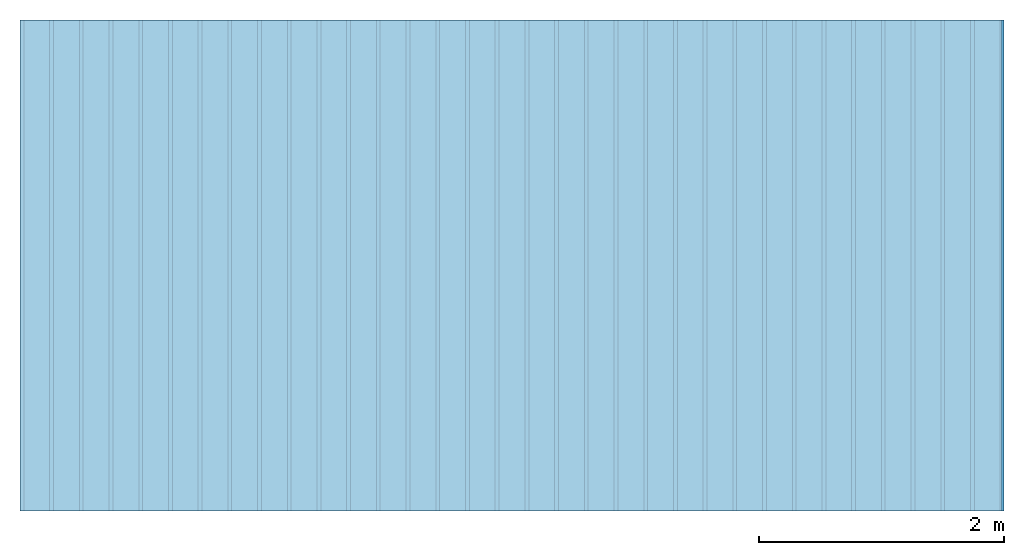
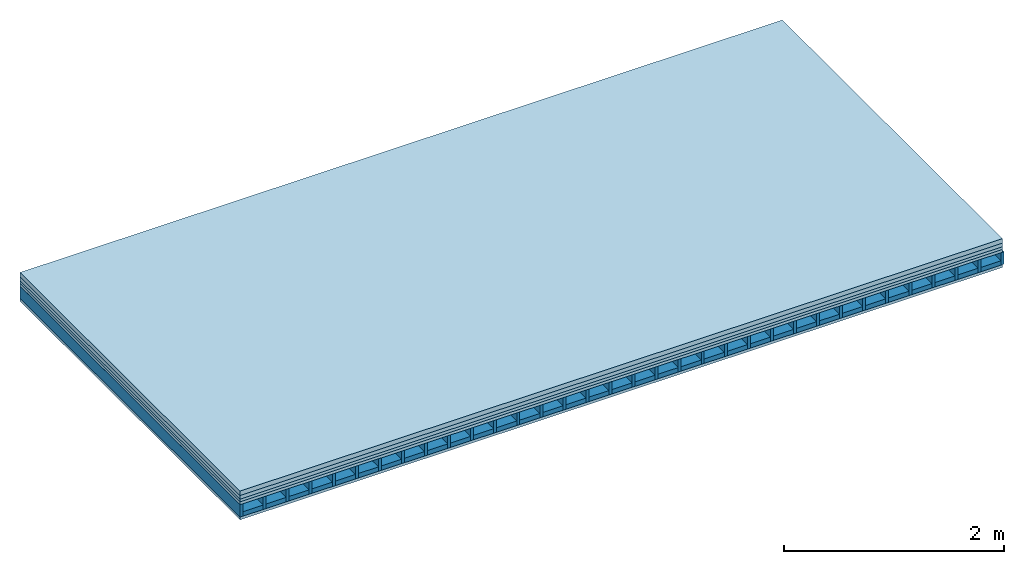
# One storey: 5 plates, 2 members, 1 element without a shape of its own.
"""IFC4 building model written with IfcOpenShell, lengths in metres."""

from ifc_helpers import new_model, si_unit, derived_unit, direction, frame, frame_2d, origin, origin_with_axes, place, context, project, spatial, rectangle, extrude, material, layer, layer_set, type_object, element, aggregate, save


model = new_model("IFC4")

# Units and contexts
plan_context = context("Plan", 3, precision=1e-05, world=origin(), true_north=direction((0.0, 1.0)))
model_context = context("Model", 3, precision=1e-05, world=origin(), true_north=direction((0.0, 1.0)))
ifc_project = project(units=[si_unit("LENGTHUNIT", "METRE"), derived_unit("SOUNDPRESSUREUNIT", [(si_unit("PRESSUREUNIT", "PASCAL", prefix="MICRO"), 0)]), si_unit("ENERGYUNIT", "JOULE", prefix="MEGA"), si_unit("MASSUNIT", "GRAM", prefix="KILO"), derived_unit("THERMALTRANSMITTANCEUNIT", [(si_unit("POWERUNIT", "WATT"), 1), (si_unit("AREAUNIT", "SQUARE_METRE"), -1), (si_unit("THERMODYNAMICTEMPERATUREUNIT", "KELVIN"), -1)]), derived_unit("AREADENSITYUNIT", [(si_unit("MASSUNIT", "GRAM", prefix="KILO"), 1), (si_unit("AREAUNIT", "SQUARE_METRE"), -1)]), derived_unit("USERDEFINED", [(si_unit("ENERGYUNIT", "JOULE", prefix="MEGA"), 1), (si_unit("AREAUNIT", "SQUARE_METRE"), -1)])], contexts=[plan_context, model_context])

# Site, building, storey
site = spatial("IfcSite", under=ifc_project)
building_placement = place(None, origin())
building = spatial("IfcBuilding", under=site, at=building_placement)
storey_placement = place(building_placement, origin())
storey = spatial("IfcBuildingStorey", under=building, at=storey_placement)

# Slab, members, plates
ifc_material_1 = material(Name="Cement screed", Category="04.006")
ifc_layer_1 = layer(ifc_material_1, 0.05, Name="On-material")
ifc_material_2 = material(Name="EP1, 40/35mm")
ifc_layer_2 = layer(ifc_material_2, 0.04, Name="Impact sound insulation")
ifc_material_3 = material(Category="03.011")
ifc_layer_3 = layer(ifc_material_3, 0.03, Name="on Supporting structure")
ifc_material_4 = material(Name="surface element sheathing above")
ifc_layer_4 = layer(ifc_material_4, 0.031, Name="Sub-floor")
ifc_layer_5 = layer(None, 0.138, Name="Supporting structure")
ifc_material_5 = material(Name="surface element sheathing below")
ifc_layer_6 = layer(ifc_material_5, 0.031, Name="Lower layer 1")
ifc_layer_set = layer_set([ifc_layer_1, ifc_layer_2, ifc_layer_3, ifc_layer_4, ifc_layer_5, ifc_layer_6])
slab_type = type_object("IfcSlabType", Name="A2704", PredefinedType="NOTDEFINED", material=ifc_layer_set)
slab_placement = place(None, frame((0.0, 0.0, 0.0), z_axis=(0.0, 0.0, -1.0), x_axis=(1.0, 0.0, 0.0)))
slab = element("IfcSlab", 1, at=slab_placement, inside=storey, type_object=slab_type, material=ifc_layer_set, Name="Slab #1")
ifc_material_6 = material(Name="surface element LFE")
member_1_placement = place(slab_placement, origin())
member_1 = element("IfcMember", 2, at=member_1_placement, material=ifc_material_6, Name="Supporting structure", context=plan_context, shape_type="SweptSolid", body=[
    extrude(rectangle(XDim=0.031, YDim=0.138, at=frame_2d((0.0155, 0.069), x_axis=(1.0, 0.0))), frame((0.0, 4.0, 0.151), z_axis=(0.0, -1.0, 0.0), x_axis=(1.0, 0.0, 0.0)), (0.0, 0.0, 1.0), 4.0),
    extrude(rectangle(XDim=0.031, YDim=0.138, at=frame_2d((0.0155, 0.069), x_axis=(1.0, 0.0))), frame((0.242, 4.0, 0.151), z_axis=(0.0, -1.0, 0.0), x_axis=(1.0, 0.0, 0.0)), (0.0, 0.0, 1.0), 4.0),
    extrude(rectangle(XDim=0.031, YDim=0.138, at=frame_2d((0.0155, 0.069), x_axis=(1.0, 0.0))), frame((0.484, 4.0, 0.151), z_axis=(0.0, -1.0, 0.0), x_axis=(1.0, 0.0, 0.0)), (0.0, 0.0, 1.0), 4.0),
    extrude(rectangle(XDim=0.031, YDim=0.138, at=frame_2d((0.0155, 0.069), x_axis=(1.0, 0.0))), frame((0.726, 4.0, 0.151), z_axis=(0.0, -1.0, 0.0), x_axis=(1.0, 0.0, 0.0)), (0.0, 0.0, 1.0), 4.0),
    extrude(rectangle(XDim=0.031, YDim=0.138, at=frame_2d((0.0155, 0.069), x_axis=(1.0, 0.0))), frame((0.968, 4.0, 0.151), z_axis=(0.0, -1.0, 0.0), x_axis=(1.0, 0.0, 0.0)), (0.0, 0.0, 1.0), 4.0),
    extrude(rectangle(XDim=0.031, YDim=0.138, at=frame_2d((0.0155, 0.069), x_axis=(1.0, 0.0))), frame((1.21, 4.0, 0.151), z_axis=(0.0, -1.0, 0.0), x_axis=(1.0, 0.0, 0.0)), (0.0, 0.0, 1.0), 4.0),
    extrude(rectangle(XDim=0.031, YDim=0.138, at=frame_2d((0.0155, 0.069), x_axis=(1.0, 0.0))), frame((1.452, 4.0, 0.151), z_axis=(0.0, -1.0, 0.0), x_axis=(1.0, 0.0, 0.0)), (0.0, 0.0, 1.0), 4.0),
    extrude(rectangle(XDim=0.031, YDim=0.138, at=frame_2d((0.0155, 0.069), x_axis=(1.0, 0.0))), frame((1.694, 4.0, 0.151), z_axis=(0.0, -1.0, 0.0), x_axis=(1.0, 0.0, 0.0)), (0.0, 0.0, 1.0), 4.0),
    extrude(rectangle(XDim=0.031, YDim=0.138, at=frame_2d((0.0155, 0.069), x_axis=(1.0, 0.0))), frame((1.936, 4.0, 0.151), z_axis=(0.0, -1.0, 0.0), x_axis=(1.0, 0.0, 0.0)), (0.0, 0.0, 1.0), 4.0),
    extrude(rectangle(XDim=0.031, YDim=0.138, at=frame_2d((0.0155, 0.069), x_axis=(1.0, 0.0))), frame((2.178, 4.0, 0.151), z_axis=(0.0, -1.0, 0.0), x_axis=(1.0, 0.0, 0.0)), (0.0, 0.0, 1.0), 4.0),
    extrude(rectangle(XDim=0.031, YDim=0.138, at=frame_2d((0.0155, 0.069), x_axis=(1.0, 0.0))), frame((2.42, 4.0, 0.151), z_axis=(0.0, -1.0, 0.0), x_axis=(1.0, 0.0, 0.0)), (0.0, 0.0, 1.0), 4.0),
    extrude(rectangle(XDim=0.031, YDim=0.138, at=frame_2d((0.0155, 0.069), x_axis=(1.0, 0.0))), frame((2.662, 4.0, 0.151), z_axis=(0.0, -1.0, 0.0), x_axis=(1.0, 0.0, 0.0)), (0.0, 0.0, 1.0), 4.0),
    extrude(rectangle(XDim=0.031, YDim=0.138, at=frame_2d((0.0155, 0.069), x_axis=(1.0, 0.0))), frame((2.904, 4.0, 0.151), z_axis=(0.0, -1.0, 0.0), x_axis=(1.0, 0.0, 0.0)), (0.0, 0.0, 1.0), 4.0),
    extrude(rectangle(XDim=0.031, YDim=0.138, at=frame_2d((0.0155, 0.069), x_axis=(1.0, 0.0))), frame((3.146, 4.0, 0.151), z_axis=(0.0, -1.0, 0.0), x_axis=(1.0, 0.0, 0.0)), (0.0, 0.0, 1.0), 4.0),
    extrude(rectangle(XDim=0.031, YDim=0.138, at=frame_2d((0.0155, 0.069), x_axis=(1.0, 0.0))), frame((3.388, 4.0, 0.151), z_axis=(0.0, -1.0, 0.0), x_axis=(1.0, 0.0, 0.0)), (0.0, 0.0, 1.0), 4.0),
    extrude(rectangle(XDim=0.031, YDim=0.138, at=frame_2d((0.0155, 0.069), x_axis=(1.0, 0.0))), frame((3.63, 4.0, 0.151), z_axis=(0.0, -1.0, 0.0), x_axis=(1.0, 0.0, 0.0)), (0.0, 0.0, 1.0), 4.0),
    extrude(rectangle(XDim=0.031, YDim=0.138, at=frame_2d((0.0155, 0.069), x_axis=(1.0, 0.0))), frame((3.872, 4.0, 0.151), z_axis=(0.0, -1.0, 0.0), x_axis=(1.0, 0.0, 0.0)), (0.0, 0.0, 1.0), 4.0),
    extrude(rectangle(XDim=0.031, YDim=0.138, at=frame_2d((0.0155, 0.069), x_axis=(1.0, 0.0))), frame((4.114, 4.0, 0.151), z_axis=(0.0, -1.0, 0.0), x_axis=(1.0, 0.0, 0.0)), (0.0, 0.0, 1.0), 4.0),
    extrude(rectangle(XDim=0.031, YDim=0.138, at=frame_2d((0.0155, 0.069), x_axis=(1.0, 0.0))), frame((4.356, 4.0, 0.151), z_axis=(0.0, -1.0, 0.0), x_axis=(1.0, 0.0, 0.0)), (0.0, 0.0, 1.0), 4.0),
    extrude(rectangle(XDim=0.031, YDim=0.138, at=frame_2d((0.0155, 0.069), x_axis=(1.0, 0.0))), frame((4.598, 4.0, 0.151), z_axis=(0.0, -1.0, 0.0), x_axis=(1.0, 0.0, 0.0)), (0.0, 0.0, 1.0), 4.0),
    extrude(rectangle(XDim=0.031, YDim=0.138, at=frame_2d((0.0155, 0.069), x_axis=(1.0, 0.0))), frame((4.84, 4.0, 0.151), z_axis=(0.0, -1.0, 0.0), x_axis=(1.0, 0.0, 0.0)), (0.0, 0.0, 1.0), 4.0),
    extrude(rectangle(XDim=0.031, YDim=0.138, at=frame_2d((0.0155, 0.069), x_axis=(1.0, 0.0))), frame((5.082, 4.0, 0.151), z_axis=(0.0, -1.0, 0.0), x_axis=(1.0, 0.0, 0.0)), (0.0, 0.0, 1.0), 4.0),
    extrude(rectangle(XDim=0.031, YDim=0.138, at=frame_2d((0.0155, 0.069), x_axis=(1.0, 0.0))), frame((5.324, 4.0, 0.151), z_axis=(0.0, -1.0, 0.0), x_axis=(1.0, 0.0, 0.0)), (0.0, 0.0, 1.0), 4.0),
    extrude(rectangle(XDim=0.031, YDim=0.138, at=frame_2d((0.0155, 0.069), x_axis=(1.0, 0.0))), frame((5.566, 4.0, 0.151), z_axis=(0.0, -1.0, 0.0), x_axis=(1.0, 0.0, 0.0)), (0.0, 0.0, 1.0), 4.0),
    extrude(rectangle(XDim=0.031, YDim=0.138, at=frame_2d((0.0155, 0.069), x_axis=(1.0, 0.0))), frame((5.808, 4.0, 0.151), z_axis=(0.0, -1.0, 0.0), x_axis=(1.0, 0.0, 0.0)), (0.0, 0.0, 1.0), 4.0),
    extrude(rectangle(XDim=0.031, YDim=0.138, at=frame_2d((0.0155, 0.069), x_axis=(1.0, 0.0))), frame((6.05, 4.0, 0.151), z_axis=(0.0, -1.0, 0.0), x_axis=(1.0, 0.0, 0.0)), (0.0, 0.0, 1.0), 4.0),
    extrude(rectangle(XDim=0.031, YDim=0.138, at=frame_2d((0.0155, 0.069), x_axis=(1.0, 0.0))), frame((6.292, 4.0, 0.151), z_axis=(0.0, -1.0, 0.0), x_axis=(1.0, 0.0, 0.0)), (0.0, 0.0, 1.0), 4.0),
    extrude(rectangle(XDim=0.031, YDim=0.138, at=frame_2d((0.0155, 0.069), x_axis=(1.0, 0.0))), frame((6.534, 4.0, 0.151), z_axis=(0.0, -1.0, 0.0), x_axis=(1.0, 0.0, 0.0)), (0.0, 0.0, 1.0), 4.0),
    extrude(rectangle(XDim=0.031, YDim=0.138, at=frame_2d((0.0155, 0.069), x_axis=(1.0, 0.0))), frame((6.776, 4.0, 0.151), z_axis=(0.0, -1.0, 0.0), x_axis=(1.0, 0.0, 0.0)), (0.0, 0.0, 1.0), 4.0),
    extrude(rectangle(XDim=0.031, YDim=0.138, at=frame_2d((0.0155, 0.069), x_axis=(1.0, 0.0))), frame((7.018, 4.0, 0.151), z_axis=(0.0, -1.0, 0.0), x_axis=(1.0, 0.0, 0.0)), (0.0, 0.0, 1.0), 4.0),
    extrude(rectangle(XDim=0.031, YDim=0.138, at=frame_2d((0.0155, 0.069), x_axis=(1.0, 0.0))), frame((7.26, 4.0, 0.151), z_axis=(0.0, -1.0, 0.0), x_axis=(1.0, 0.0, 0.0)), (0.0, 0.0, 1.0), 4.0),
    extrude(rectangle(XDim=0.031, YDim=0.138, at=frame_2d((0.0155, 0.069), x_axis=(1.0, 0.0))), frame((7.502, 4.0, 0.151), z_axis=(0.0, -1.0, 0.0), x_axis=(1.0, 0.0, 0.0)), (0.0, 0.0, 1.0), 4.0),
    extrude(rectangle(XDim=0.031, YDim=0.138, at=frame_2d((0.0155, 0.069), x_axis=(1.0, 0.0))), frame((7.744, 4.0, 0.151), z_axis=(0.0, -1.0, 0.0), x_axis=(1.0, 0.0, 0.0)), (0.0, 0.0, 1.0), 4.0),
    extrude(rectangle(XDim=0.031, YDim=0.138, at=frame_2d((0.0155, 0.069), x_axis=(1.0, 0.0))), frame((7.986, 4.0, 0.151), z_axis=(0.0, -1.0, 0.0), x_axis=(1.0, 0.0, 0.0)), (0.0, 0.0, 1.0), 4.0),
])
member_2_placement = place(slab_placement, origin())
member_2 = element("IfcMember", 3, at=member_2_placement, material=ifc_material_3, Name="in supporting structure", context=plan_context, shape_type="SweptSolid", body=[
    extrude(rectangle(XDim=0.211, YDim=0.049, at=frame_2d((0.1055, 0.0245), x_axis=(1.0, 0.0))), frame((0.031, 4.0, 0.24), z_axis=(0.0, -1.0, 0.0), x_axis=(1.0, 0.0, 0.0)), (0.0, 0.0, 1.0), 4.0),
    extrude(rectangle(XDim=0.211, YDim=0.049, at=frame_2d((0.1055, 0.0245), x_axis=(1.0, 0.0))), frame((0.273, 4.0, 0.24), z_axis=(0.0, -1.0, 0.0), x_axis=(1.0, 0.0, 0.0)), (0.0, 0.0, 1.0), 4.0),
    extrude(rectangle(XDim=0.211, YDim=0.049, at=frame_2d((0.1055, 0.0245), x_axis=(1.0, 0.0))), frame((0.515, 4.0, 0.24), z_axis=(0.0, -1.0, 0.0), x_axis=(1.0, 0.0, 0.0)), (0.0, 0.0, 1.0), 4.0),
    extrude(rectangle(XDim=0.211, YDim=0.049, at=frame_2d((0.1055, 0.0245), x_axis=(1.0, 0.0))), frame((0.757, 4.0, 0.24), z_axis=(0.0, -1.0, 0.0), x_axis=(1.0, 0.0, 0.0)), (0.0, 0.0, 1.0), 4.0),
    extrude(rectangle(XDim=0.211, YDim=0.049, at=frame_2d((0.1055, 0.0245), x_axis=(1.0, 0.0))), frame((0.999, 4.0, 0.24), z_axis=(0.0, -1.0, 0.0), x_axis=(1.0, 0.0, 0.0)), (0.0, 0.0, 1.0), 4.0),
    extrude(rectangle(XDim=0.211, YDim=0.049, at=frame_2d((0.1055, 0.0245), x_axis=(1.0, 0.0))), frame((1.241, 4.0, 0.24), z_axis=(0.0, -1.0, 0.0), x_axis=(1.0, 0.0, 0.0)), (0.0, 0.0, 1.0), 4.0),
    extrude(rectangle(XDim=0.211, YDim=0.049, at=frame_2d((0.1055, 0.0245), x_axis=(1.0, 0.0))), frame((1.483, 4.0, 0.24), z_axis=(0.0, -1.0, 0.0), x_axis=(1.0, 0.0, 0.0)), (0.0, 0.0, 1.0), 4.0),
    extrude(rectangle(XDim=0.211, YDim=0.049, at=frame_2d((0.1055, 0.0245), x_axis=(1.0, 0.0))), frame((1.725, 4.0, 0.24), z_axis=(0.0, -1.0, 0.0), x_axis=(1.0, 0.0, 0.0)), (0.0, 0.0, 1.0), 4.0),
    extrude(rectangle(XDim=0.211, YDim=0.049, at=frame_2d((0.1055, 0.0245), x_axis=(1.0, 0.0))), frame((1.967, 4.0, 0.24), z_axis=(0.0, -1.0, 0.0), x_axis=(1.0, 0.0, 0.0)), (0.0, 0.0, 1.0), 4.0),
    extrude(rectangle(XDim=0.211, YDim=0.049, at=frame_2d((0.1055, 0.0245), x_axis=(1.0, 0.0))), frame((2.209, 4.0, 0.24), z_axis=(0.0, -1.0, 0.0), x_axis=(1.0, 0.0, 0.0)), (0.0, 0.0, 1.0), 4.0),
    extrude(rectangle(XDim=0.211, YDim=0.049, at=frame_2d((0.1055, 0.0245), x_axis=(1.0, 0.0))), frame((2.451, 4.0, 0.24), z_axis=(0.0, -1.0, 0.0), x_axis=(1.0, 0.0, 0.0)), (0.0, 0.0, 1.0), 4.0),
    extrude(rectangle(XDim=0.211, YDim=0.049, at=frame_2d((0.1055, 0.0245), x_axis=(1.0, 0.0))), frame((2.693, 4.0, 0.24), z_axis=(0.0, -1.0, 0.0), x_axis=(1.0, 0.0, 0.0)), (0.0, 0.0, 1.0), 4.0),
    extrude(rectangle(XDim=0.211, YDim=0.049, at=frame_2d((0.1055, 0.0245), x_axis=(1.0, 0.0))), frame((2.935, 4.0, 0.24), z_axis=(0.0, -1.0, 0.0), x_axis=(1.0, 0.0, 0.0)), (0.0, 0.0, 1.0), 4.0),
    extrude(rectangle(XDim=0.211, YDim=0.049, at=frame_2d((0.1055, 0.0245), x_axis=(1.0, 0.0))), frame((3.177, 4.0, 0.24), z_axis=(0.0, -1.0, 0.0), x_axis=(1.0, 0.0, 0.0)), (0.0, 0.0, 1.0), 4.0),
    extrude(rectangle(XDim=0.211, YDim=0.049, at=frame_2d((0.1055, 0.0245), x_axis=(1.0, 0.0))), frame((3.419, 4.0, 0.24), z_axis=(0.0, -1.0, 0.0), x_axis=(1.0, 0.0, 0.0)), (0.0, 0.0, 1.0), 4.0),
    extrude(rectangle(XDim=0.211, YDim=0.049, at=frame_2d((0.1055, 0.0245), x_axis=(1.0, 0.0))), frame((3.661, 4.0, 0.24), z_axis=(0.0, -1.0, 0.0), x_axis=(1.0, 0.0, 0.0)), (0.0, 0.0, 1.0), 4.0),
    extrude(rectangle(XDim=0.211, YDim=0.049, at=frame_2d((0.1055, 0.0245), x_axis=(1.0, 0.0))), frame((3.903, 4.0, 0.24), z_axis=(0.0, -1.0, 0.0), x_axis=(1.0, 0.0, 0.0)), (0.0, 0.0, 1.0), 4.0),
    extrude(rectangle(XDim=0.211, YDim=0.049, at=frame_2d((0.1055, 0.0245), x_axis=(1.0, 0.0))), frame((4.145, 4.0, 0.24), z_axis=(0.0, -1.0, 0.0), x_axis=(1.0, 0.0, 0.0)), (0.0, 0.0, 1.0), 4.0),
    extrude(rectangle(XDim=0.211, YDim=0.049, at=frame_2d((0.1055, 0.0245), x_axis=(1.0, 0.0))), frame((4.387, 4.0, 0.24), z_axis=(0.0, -1.0, 0.0), x_axis=(1.0, 0.0, 0.0)), (0.0, 0.0, 1.0), 4.0),
    extrude(rectangle(XDim=0.211, YDim=0.049, at=frame_2d((0.1055, 0.0245), x_axis=(1.0, 0.0))), frame((4.629, 4.0, 0.24), z_axis=(0.0, -1.0, 0.0), x_axis=(1.0, 0.0, 0.0)), (0.0, 0.0, 1.0), 4.0),
    extrude(rectangle(XDim=0.211, YDim=0.049, at=frame_2d((0.1055, 0.0245), x_axis=(1.0, 0.0))), frame((4.871, 4.0, 0.24), z_axis=(0.0, -1.0, 0.0), x_axis=(1.0, 0.0, 0.0)), (0.0, 0.0, 1.0), 4.0),
    extrude(rectangle(XDim=0.211, YDim=0.049, at=frame_2d((0.1055, 0.0245), x_axis=(1.0, 0.0))), frame((5.113, 4.0, 0.24), z_axis=(0.0, -1.0, 0.0), x_axis=(1.0, 0.0, 0.0)), (0.0, 0.0, 1.0), 4.0),
    extrude(rectangle(XDim=0.211, YDim=0.049, at=frame_2d((0.1055, 0.0245), x_axis=(1.0, 0.0))), frame((5.355, 4.0, 0.24), z_axis=(0.0, -1.0, 0.0), x_axis=(1.0, 0.0, 0.0)), (0.0, 0.0, 1.0), 4.0),
    extrude(rectangle(XDim=0.211, YDim=0.049, at=frame_2d((0.1055, 0.0245), x_axis=(1.0, 0.0))), frame((5.597, 4.0, 0.24), z_axis=(0.0, -1.0, 0.0), x_axis=(1.0, 0.0, 0.0)), (0.0, 0.0, 1.0), 4.0),
    extrude(rectangle(XDim=0.211, YDim=0.049, at=frame_2d((0.1055, 0.0245), x_axis=(1.0, 0.0))), frame((5.839, 4.0, 0.24), z_axis=(0.0, -1.0, 0.0), x_axis=(1.0, 0.0, 0.0)), (0.0, 0.0, 1.0), 4.0),
    extrude(rectangle(XDim=0.211, YDim=0.049, at=frame_2d((0.1055, 0.0245), x_axis=(1.0, 0.0))), frame((6.081, 4.0, 0.24), z_axis=(0.0, -1.0, 0.0), x_axis=(1.0, 0.0, 0.0)), (0.0, 0.0, 1.0), 4.0),
    extrude(rectangle(XDim=0.211, YDim=0.049, at=frame_2d((0.1055, 0.0245), x_axis=(1.0, 0.0))), frame((6.323, 4.0, 0.24), z_axis=(0.0, -1.0, 0.0), x_axis=(1.0, 0.0, 0.0)), (0.0, 0.0, 1.0), 4.0),
    extrude(rectangle(XDim=0.211, YDim=0.049, at=frame_2d((0.1055, 0.0245), x_axis=(1.0, 0.0))), frame((6.565, 4.0, 0.24), z_axis=(0.0, -1.0, 0.0), x_axis=(1.0, 0.0, 0.0)), (0.0, 0.0, 1.0), 4.0),
    extrude(rectangle(XDim=0.211, YDim=0.049, at=frame_2d((0.1055, 0.0245), x_axis=(1.0, 0.0))), frame((6.807, 4.0, 0.24), z_axis=(0.0, -1.0, 0.0), x_axis=(1.0, 0.0, 0.0)), (0.0, 0.0, 1.0), 4.0),
    extrude(rectangle(XDim=0.211, YDim=0.049, at=frame_2d((0.1055, 0.0245), x_axis=(1.0, 0.0))), frame((7.049, 4.0, 0.24), z_axis=(0.0, -1.0, 0.0), x_axis=(1.0, 0.0, 0.0)), (0.0, 0.0, 1.0), 4.0),
    extrude(rectangle(XDim=0.211, YDim=0.049, at=frame_2d((0.1055, 0.0245), x_axis=(1.0, 0.0))), frame((7.291, 4.0, 0.24), z_axis=(0.0, -1.0, 0.0), x_axis=(1.0, 0.0, 0.0)), (0.0, 0.0, 1.0), 4.0),
    extrude(rectangle(XDim=0.211, YDim=0.049, at=frame_2d((0.1055, 0.0245), x_axis=(1.0, 0.0))), frame((7.533, 4.0, 0.24), z_axis=(0.0, -1.0, 0.0), x_axis=(1.0, 0.0, 0.0)), (0.0, 0.0, 1.0), 4.0),
    extrude(rectangle(XDim=0.211, YDim=0.049, at=frame_2d((0.1055, 0.0245), x_axis=(1.0, 0.0))), frame((7.775, 4.0, 0.24), z_axis=(0.0, -1.0, 0.0), x_axis=(1.0, 0.0, 0.0)), (0.0, 0.0, 1.0), 4.0),
])
plate_1_placement = place(slab_placement, origin())
plate_1 = element("IfcPlate", 4, at=plate_1_placement, material=ifc_material_1, Name="On-material", context=plan_context, shape_type="SweptSolid", body=[
    extrude(rectangle(XDim=8.0, YDim=4.0, at=frame_2d((4.0, 2.0), x_axis=(1.0, 0.0))), origin_with_axes(), (0.0, 0.0, 1.0), 0.05),
])
plate_2_placement = place(slab_placement, origin())
plate_2 = element("IfcPlate", 5, at=plate_2_placement, material=ifc_material_2, Name="Impact sound insulation", context=plan_context, shape_type="SweptSolid", body=[
    extrude(rectangle(XDim=8.0, YDim=4.0, at=frame_2d((4.0, 2.0), x_axis=(1.0, 0.0))), frame((0.0, 0.0, 0.05), z_axis=(0.0, 0.0, 1.0), x_axis=(1.0, 0.0, 0.0)), (0.0, 0.0, 1.0), 0.04),
])
plate_3_placement = place(slab_placement, origin())
plate_3 = element("IfcPlate", 6, at=plate_3_placement, material=ifc_material_3, Name="on Supporting structure", context=plan_context, shape_type="SweptSolid", body=[
    extrude(rectangle(XDim=8.0, YDim=4.0, at=frame_2d((4.0, 2.0), x_axis=(1.0, 0.0))), frame((0.0, 0.0, 0.09), z_axis=(0.0, 0.0, 1.0), x_axis=(1.0, 0.0, 0.0)), (0.0, 0.0, 1.0), 0.03),
])
plate_4_placement = place(slab_placement, origin())
plate_4 = element("IfcPlate", 7, at=plate_4_placement, material=ifc_material_4, Name="Sub-floor", context=plan_context, shape_type="SweptSolid", body=[
    extrude(rectangle(XDim=8.0, YDim=4.0, at=frame_2d((4.0, 2.0), x_axis=(1.0, 0.0))), frame((0.0, 0.0, 0.12), z_axis=(0.0, 0.0, 1.0), x_axis=(1.0, 0.0, 0.0)), (0.0, 0.0, 1.0), 0.031),
])
plate_5_placement = place(slab_placement, origin())
plate_5 = element("IfcPlate", 8, at=plate_5_placement, material=ifc_material_5, Name="Lower layer 1", context=plan_context, shape_type="SweptSolid", body=[
    extrude(rectangle(XDim=8.0, YDim=4.0, at=frame_2d((4.0, 2.0), x_axis=(1.0, 0.0))), frame((0.0, 0.0, 0.289), z_axis=(0.0, 0.0, 1.0), x_axis=(1.0, 0.0, 0.0)), (0.0, 0.0, 1.0), 0.031),
])
aggregate(slab, [plate_1, plate_2, plate_3, plate_4, member_1, member_2, plate_5])

save(model, "model.ifc")
